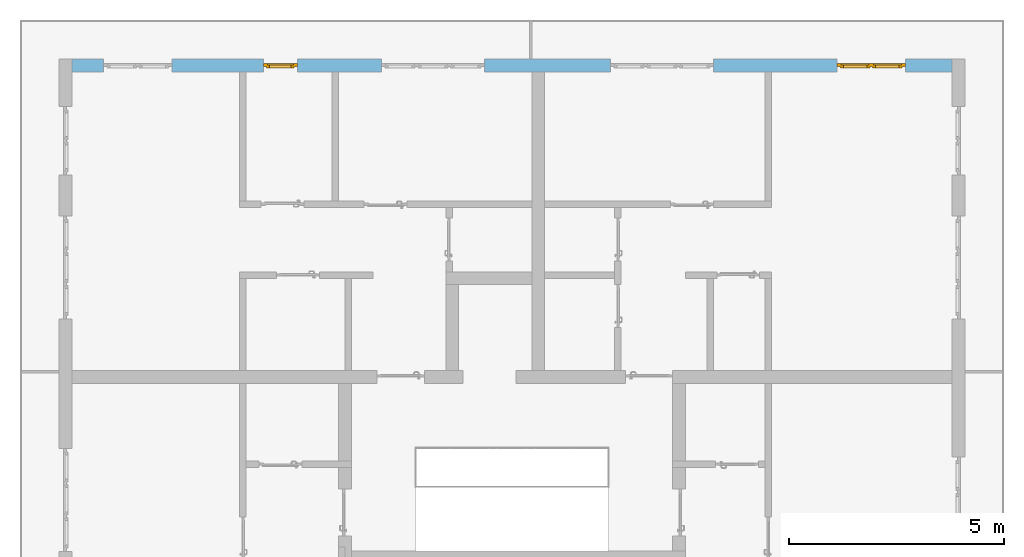
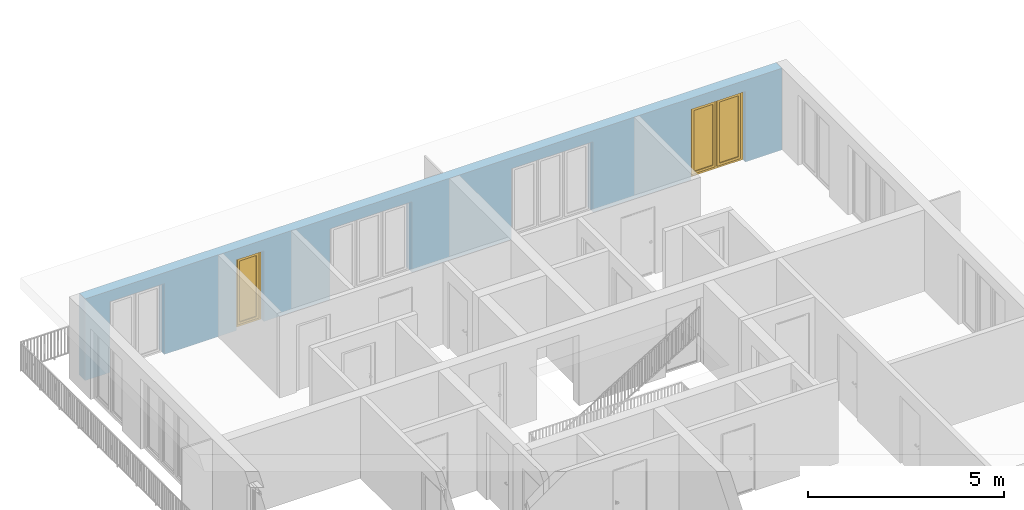
# One storey, part 27 of 54: 2 windows, 5 openings, plus 1 element that does not belong to this part.
"""IFC4 building model written with IfcOpenShell, lengths in metres."""

from ifc_helpers import new_model, entity, si_unit, converted_unit, derived_unit, direction, frame, origin_with_axes, place, context, subcontext, project, spatial, polygons, source, transform, mapped, material, type_object, element, fill, save


model = new_model("IFC4")

# Units and contexts
model_context = context("Model", 3, precision=1e-05, world=origin_with_axes(), true_north=direction((0.0, 1.0)))
body_context = subcontext(model_context, "Body", "Model", "MODEL_VIEW")
ifc_project = project(units=[si_unit("LENGTHUNIT", "METRE"), si_unit("AREAUNIT", "SQUARE_METRE"), si_unit("VOLUMEUNIT", "CUBIC_METRE"), converted_unit("PLANEANGLEUNIT", "DEGREE", entity("IfcPlaneAngleMeasure", 0.0174532925199), si_unit("PLANEANGLEUNIT", "RADIAN"), dimensions=[0, 0, 0, 0, 0, 0, 0]), converted_unit("TIMEUNIT", "Year", entity("IfcTimeMeasure", 31556926.0), si_unit("TIMEUNIT", "SECOND"), dimensions=[0, 0, 1, 0, 0, 0, 0]), si_unit("MASSUNIT", "GRAM", prefix="KILO"), si_unit("THERMODYNAMICTEMPERATUREUNIT", "DEGREE_CELSIUS"), si_unit("LUMINOUSINTENSITYUNIT", "LUMEN"), si_unit("ENERGYUNIT", "JOULE", prefix="MEGA"), derived_unit("THERMALCONDUCTANCEUNIT", [(si_unit("POWERUNIT", "WATT"), 1), (si_unit("LENGTHUNIT", "METRE"), -1), (si_unit("THERMODYNAMICTEMPERATUREUNIT", "KELVIN"), -1)]), derived_unit("SPECIFICHEATCAPACITYUNIT", [(si_unit("ENERGYUNIT", "JOULE"), 1), (si_unit("MASSUNIT", "GRAM", prefix="KILO"), -1), (si_unit("THERMODYNAMICTEMPERATUREUNIT", "KELVIN"), -1)]), derived_unit("MASSDENSITYUNIT", [(si_unit("MASSUNIT", "GRAM", prefix="KILO"), 1), (si_unit("VOLUMEUNIT", "CUBIC_METRE"), -1)])], contexts=[model_context])

# Site, building, storey
site_placement = place(None, origin_with_axes())
site = spatial("IfcSite", under=ifc_project, at=site_placement, CompositionType="ELEMENT")
building_placement = place(site_placement, origin_with_axes())
building = spatial("IfcBuilding", under=site, at=building_placement, CompositionType="ELEMENT")
storey_placement = place(building_placement, frame((0.0, 0.0, 6.29), z_axis=(0.0, 0.0, 1.0), x_axis=(1.0, 0.0, 0.0)))
storey = spatial("IfcBuildingStorey", under=building, at=storey_placement, Name="2. Geschoss", CompositionType="ELEMENT", Elevation=6.29)

# Wall, openings, windows
ifc_material = material()
wall_type = type_object("IfcWallType", Name="300", PredefinedType="NOTDEFINED")
wall_placement = place(storey_placement, frame((-11.7421993804, 8.92118776896, 0.0), z_axis=(0.0, 0.0, 1.0), x_axis=(1.0, 0.0, 0.0)))
wall = element("IfcWall", 1, at=wall_placement, inside=storey, type_object=wall_type, material=ifc_material, Name="Wand-001", PredefinedType="NOTDEFINED", context=body_context, shape_type="Tessellation", body=[
    polygons([(15.23, -0.1, 0.0), (15.23, -0.3, 0.0), (15.23, -0.3, 2.2), (15.23, 0.0, 2.2), (15.23, 0.0, 0.0), (18.102139809, 0.0, 0.0), (18.102139809, -0.3, 0.0), (18.102139809, -0.3, 2.2), (19.702139809, -0.3, 2.2), (19.702139809, -0.3, 0.0), (20.78, -0.3, 0.0), (20.78, -0.3, 2.54), (0.3, -0.3, 2.54), (0.3, -0.3, 0.0), (1.0288518641, -0.3, 0.0), (1.0288518641, -0.3, 2.2), (2.6288518641, -0.3, 2.2), (2.6288518641, -0.3, 0.0), (4.75, -0.3, 0.0), (4.75, -0.3, 2.2), (5.55, -0.3, 2.2), (5.55, -0.3, 0.0), (7.50089858046, -0.3, 0.0), (7.50089858046, -0.3, 2.2), (9.90089858046, -0.3, 2.2), (9.90089858046, -0.3, 0.0), (12.83, -0.3, 0.0), (12.83, -0.3, 2.2), (12.83, 0.0, 2.2), (12.83, 0.0, 0.0), (9.90089858046, 0.0, 0.0), (9.90089858046, 0.0, 2.2), (7.50089858046, 0.0, 2.2), (7.50089858046, 0.0, 0.0), (5.55, 0.0, 0.0), (5.55, 0.0, 2.2), (4.75, 0.0, 2.2), (4.75, 0.0, 0.0), (2.6288518641, 0.0, 0.0), (2.6288518641, 0.0, 2.2), (1.0288518641, 0.0, 2.2), (1.0288518641, 0.0, 0.0), (0.3, 0.0, 0.0), (0.3, 0.0, 2.54), (20.78, 0.0, 2.54), (20.78, 0.0, 0.0), (19.702139809, 0.0, 0.0), (19.702139809, 0.0, 2.2), (18.102139809, 0.0, 2.2), (12.83, -0.1, 0.0)], [[[1, 2, 3, 4, 5]], [[2, 1, 5, 6, 7]], [[3, 2, 7, 8, 9, 10, 11, 12, 13, 14, 15, 16, 17, 18, 19, 20, 21, 22, 23, 24, 25, 26, 27, 28]], [[4, 3, 28, 29]], [[6, 5, 4, 29, 30, 31, 32, 33, 34, 35, 36, 37, 38, 39, 40, 41, 42, 43, 44, 45, 46, 47, 48, 49]], [[6, 49, 8, 7]], [[8, 49, 48, 9]], [[48, 47, 10, 9]], [[46, 11, 10, 47]], [[12, 11, 46, 45]], [[45, 44, 13, 12]], [[44, 43, 14, 13]], [[15, 14, 43, 42]], [[16, 15, 42, 41]], [[40, 17, 16, 41]], [[18, 17, 40, 39]], [[19, 18, 39, 38]], [[20, 19, 38, 37]], [[36, 21, 20, 37]], [[22, 21, 36, 35]], [[22, 35, 34, 23]], [[34, 33, 24, 23]], [[24, 33, 32, 25]], [[32, 31, 26, 25]], [[50, 27, 26, 31, 30]], [[28, 27, 50, 30, 29]]], closed=True),
])
opening_1_placement = place(wall_placement, frame((1.8288518641, 0.0, 0.0), z_axis=(0.0, 0.0, 1.0), x_axis=(1.0, 0.0, 0.0)))
element("IfcOpeningElement", 2, at=opening_1_placement, cuts=wall, Name="Fenster-001", context=body_context, identifier="Reference", shape_type="Tessellation", body=[
    polygons([(-0.8, -0.1, 0.0), (-0.8, -0.1, 2.2), (-0.8, 0.000999999999998, 2.2), (-0.8, 0.000999999999998, 0.0), (-0.8, -0.301, 0.0), (-0.8, -0.301, 2.2), (0.8, -0.1, 2.2), (0.8, 0.000999999999999, 2.2), (0.8, -0.301, 2.2), (0.8, 0.000999999999999, 0.0), (0.8, -0.1, 0.0), (0.8, -0.301, 0.0)], [[[1, 2, 3, 4]], [[2, 1, 5, 6]], [[7, 8, 3, 2, 6, 9]], [[8, 10, 4, 3]], [[1, 4, 10, 11, 12, 5]], [[6, 5, 12, 9]], [[7, 11, 10, 8]], [[11, 7, 9, 12]]], closed=True),
])
opening_2_placement = place(wall_placement, frame((8.70089858046, 0.0, 0.0), z_axis=(0.0, 0.0, 1.0), x_axis=(1.0, 0.0, 0.0)))
element("IfcOpeningElement", 3, at=opening_2_placement, cuts=wall, Name="Fenster-002", context=body_context, identifier="Reference", shape_type="Tessellation", body=[
    polygons([(-1.2, -0.1, 0.0), (-1.2, -0.1, 2.2), (-1.2, 0.000999999999999, 2.2), (-1.2, 0.000999999999999, 0.0), (-1.2, -0.301, 0.0), (-1.2, -0.301, 2.2), (1.2, -0.1, 2.2), (1.2, 0.001, 2.2), (1.2, -0.301, 2.2), (1.2, 0.001, 0.0), (1.2, -0.1, 0.0), (1.2, -0.301, 0.0)], [[[1, 2, 3, 4]], [[2, 1, 5, 6]], [[7, 8, 3, 2, 6, 9]], [[8, 10, 4, 3]], [[1, 4, 10, 11, 12, 5]], [[6, 5, 12, 9]], [[7, 11, 10, 8]], [[11, 7, 9, 12]]], closed=True),
])
opening_3_placement = place(wall_placement, frame((5.15, 0.0, 0.0), z_axis=(0.0, 0.0, 1.0), x_axis=(1.0, 0.0, 0.0)))
opening_3 = element("IfcOpeningElement", 4, at=opening_3_placement, cuts=wall, Name="Fenster-003", context=body_context, identifier="Reference", shape_type="Tessellation", body=[
    polygons([(-0.4, -0.1, 0.0), (-0.4, -0.1, 2.2), (-0.4, 0.001, 2.2), (-0.4, 0.001, 0.0), (-0.4, -0.301, 0.0), (-0.4, -0.301, 2.2), (0.4, -0.1, 2.2), (0.4, 0.001, 2.2), (0.4, -0.301, 2.2), (0.4, 0.001, 0.0), (0.4, -0.1, 0.0), (0.4, -0.301, 0.0)], [[[1, 2, 3, 4]], [[2, 1, 5, 6]], [[7, 8, 3, 2, 6, 9]], [[8, 10, 4, 3]], [[1, 4, 10, 11, 12, 5]], [[6, 5, 12, 9]], [[7, 11, 10, 8]], [[11, 7, 9, 12]]], closed=True),
])
opening_4_placement = place(wall_placement, frame((18.902139809, 0.0, 0.0), z_axis=(0.0, 0.0, 1.0), x_axis=(1.0, 0.0, 0.0)))
opening_4 = element("IfcOpeningElement", 5, at=opening_4_placement, cuts=wall, Name="Fenster-001", context=body_context, identifier="Reference", shape_type="Tessellation", body=[
    polygons([(-0.8, -0.1, 0.0), (-0.8, -0.1, 2.2), (-0.8, 0.001, 2.2), (-0.8, 0.001, 0.0), (-0.8, -0.301, 0.0), (-0.8, -0.301, 2.2), (0.8, -0.1, 2.2), (0.8, 0.001, 2.2), (0.8, -0.301, 2.2), (0.8, 0.001, 0.0), (0.8, -0.1, 0.0), (0.8, -0.301, 0.0)], [[[1, 2, 3, 4]], [[2, 1, 5, 6]], [[7, 8, 3, 2, 6, 9]], [[8, 10, 4, 3]], [[1, 4, 10, 11, 12, 5]], [[6, 5, 12, 9]], [[7, 11, 10, 8]], [[11, 7, 9, 12]]], closed=True),
])
opening_5_placement = place(wall_placement, frame((14.03, 0.0, 0.0), z_axis=(0.0, 0.0, 1.0), x_axis=(1.0, 0.0, 0.0)))
element("IfcOpeningElement", 6, at=opening_5_placement, cuts=wall, Name="Fenster-002", context=body_context, identifier="Reference", shape_type="Tessellation", body=[
    polygons([(-1.2, -0.1, 0.0), (-1.2, -0.1, 2.2), (-1.2, 0.001, 2.2), (-1.2, 0.001, 0.0), (-1.2, -0.301, 0.0), (-1.2, -0.301, 2.2), (1.2, -0.1, 2.2), (1.2, 0.001, 2.2), (1.2, -0.301, 2.2), (1.2, 0.001, 0.0), (1.2, -0.1, 0.0), (1.2, -0.301, 0.0)], [[[1, 2, 3, 4]], [[2, 1, 5, 6]], [[7, 8, 3, 2, 6, 9]], [[8, 10, 4, 3]], [[1, 4, 10, 11, 12, 5]], [[6, 5, 12, 9]], [[7, 11, 10, 8]], [[11, 7, 9, 12]]], closed=True),
])
window_type_1 = type_object("IfcWindowType", Name="2-1+1 26", PartitioningType="DOUBLE_PANEL_VERTICAL", PredefinedType="WINDOW")
shared_shape_1 = source(origin_with_axes(), body_context, "Body", "Tessellation", [
    polygons([(-0.8, -0.07, 0.0), (-0.8, 0.0, 0.0), (-0.7, 0.0, 0.1), (-0.7, -0.07, 0.1), (-0.8, -0.07, 2.2), (-0.8, 0.0, 2.2), (-0.7, 0.0, 2.1), (-0.7, -0.07, 2.1)], [[[1, 2, 3, 4]], [[5, 6, 2, 1]], [[2, 6, 7, 3]], [[4, 3, 7, 8]], [[1, 4, 8, 5]], [[8, 7, 6, 5]]], closed=True),
    polygons([(0.8, -0.07, 0.0), (0.8, 0.0, 0.0), (0.8, 0.0, 2.2), (0.8, -0.07, 2.2), (0.7, -0.07, 0.1), (0.7, 0.0, 0.1), (0.7, 0.0, 2.1), (0.7, -0.07, 2.1)], [[[1, 2, 3, 4]], [[5, 6, 2, 1]], [[2, 6, 7, 3]], [[4, 3, 7, 8]], [[1, 4, 8, 5]], [[8, 7, 6, 5]]], closed=True),
    polygons([(-0.8, -0.07, 0.0), (-0.8, 0.0, 0.0), (0.8, 0.0, 0.0), (0.8, -0.07, 0.0), (-0.7, -0.07, 0.1), (-0.7, 0.0, 0.1), (-0.05, 0.0, 0.1), (0.05, 0.0, 0.1), (0.7, 0.0, 0.1), (0.7, -0.07, 0.1), (0.05, -0.07, 0.1), (-0.05, -0.07, 0.1)], [[[1, 2, 3, 4]], [[5, 6, 2, 1]], [[2, 6, 7, 8, 9, 3]], [[4, 3, 9, 10]], [[1, 4, 10, 11, 12, 5]], [[12, 7, 6, 5]], [[11, 8, 7, 12]], [[10, 9, 8, 11]]], closed=True),
    polygons([(-0.8, -0.07, 2.2), (-0.8, 0.0, 2.2), (-0.7, 0.0, 2.1), (-0.7, -0.07, 2.1), (0.8, -0.07, 2.2), (0.8, 0.0, 2.2), (0.7, 0.0, 2.1), (0.05, 0.0, 2.1), (-0.05, 0.0, 2.1), (-0.05, -0.07, 2.1), (0.05, -0.07, 2.1), (0.7, -0.07, 2.1)], [[[1, 2, 3, 4]], [[5, 6, 2, 1]], [[2, 6, 7, 8, 9, 3]], [[4, 3, 9, 10]], [[1, 4, 10, 11, 12, 5]], [[12, 7, 6, 5]], [[11, 8, 7, 12]], [[10, 9, 8, 11]]], closed=True),
    polygons([(-0.05, -0.07, 0.1), (-0.05, 0.0, 0.1), (0.05, 0.0, 0.1), (0.05, -0.07, 0.1), (-0.05, -0.07, 2.1), (-0.05, 0.0, 2.1), (0.05, 0.0, 2.1), (0.05, -0.07, 2.1)], [[[1, 2, 3, 4]], [[5, 6, 2, 1]], [[2, 6, 7, 3]], [[4, 3, 7, 8]], [[1, 4, 8, 5]], [[8, 7, 6, 5]]], closed=True),
    polygons([(-0.72, 0.0, 0.08), (-0.72, 0.03, 0.08), (-0.65, 0.03, 0.15), (-0.65, 0.0, 0.15), (-0.72, 0.0, 2.12), (-0.72, 0.03, 2.12), (-0.65, 0.03, 2.05), (-0.65, 0.0, 2.05)], [[[1, 2, 3, 4]], [[5, 6, 2, 1]], [[2, 6, 7, 3]], [[4, 3, 7, 8]], [[1, 4, 8, 5]], [[8, 7, 6, 5]]], closed=True),
    polygons([(-0.03, 0.0, 0.08), (-0.1, 0.0, 0.15), (-0.1, 0.03, 0.15), (-0.03, 0.03, 0.08), (-0.03, 0.0, 2.12), (-0.1, 0.0, 2.05), (-0.1, 0.03, 2.05), (-0.03, 0.03, 2.12)], [[[1, 2, 3, 4]], [[1, 5, 6, 2]], [[2, 6, 7, 3]], [[4, 3, 7, 8]], [[5, 1, 4, 8]], [[6, 5, 8, 7]]], closed=True),
    polygons([(-0.72, 0.0, 0.08), (-0.72, 0.03, 0.08), (-0.03, 0.03, 0.08), (-0.03, 0.0, 0.08), (-0.65, 0.0, 0.15), (-0.65, 0.03, 0.15), (-0.1, 0.03, 0.15), (-0.1, 0.0, 0.15)], [[[1, 2, 3, 4]], [[5, 6, 2, 1]], [[2, 6, 7, 3]], [[4, 3, 7, 8]], [[1, 4, 8, 5]], [[8, 7, 6, 5]]], closed=True),
    polygons([(-0.72, 0.0, 2.12), (-0.03, 0.0, 2.12), (-0.03, 0.03, 2.12), (-0.72, 0.03, 2.12), (-0.65, 0.0, 2.05), (-0.1, 0.0, 2.05), (-0.1, 0.03, 2.05), (-0.65, 0.03, 2.05)], [[[1, 2, 3, 4]], [[1, 5, 6, 2]], [[2, 6, 7, 3]], [[4, 3, 7, 8]], [[5, 1, 4, 8]], [[6, 5, 8, 7]]], closed=True),
    polygons([(-0.7, -0.03, 0.1), (-0.7, 0.0, 0.1), (-0.65, 0.0, 0.15), (-0.65, -0.03, 0.15), (-0.7, -0.03, 2.1), (-0.7, 0.0, 2.1), (-0.65, 0.0, 2.05), (-0.65, -0.03, 2.05)], [[[1, 2, 3, 4]], [[5, 6, 2, 1]], [[2, 6, 7, 3]], [[4, 3, 7, 8]], [[1, 4, 8, 5]], [[8, 7, 6, 5]]], closed=True),
    polygons([(-0.05, -0.03, 0.1), (-0.1, -0.03, 0.15), (-0.1, 0.0, 0.15), (-0.05, 0.0, 0.1), (-0.05, -0.03, 2.1), (-0.1, -0.03, 2.05), (-0.1, 0.0, 2.05), (-0.05, 0.0, 2.1)], [[[1, 2, 3, 4]], [[1, 5, 6, 2]], [[2, 6, 7, 3]], [[4, 3, 7, 8]], [[5, 1, 4, 8]], [[6, 5, 8, 7]]], closed=True),
    polygons([(-0.7, -0.03, 0.1), (-0.7, 0.0, 0.1), (-0.05, 0.0, 0.1), (-0.05, -0.03, 0.1), (-0.65, -0.03, 0.15), (-0.65, 0.0, 0.15), (-0.1, 0.0, 0.15), (-0.1, -0.03, 0.15)], [[[1, 2, 3, 4]], [[5, 6, 2, 1]], [[2, 6, 7, 3]], [[4, 3, 7, 8]], [[1, 4, 8, 5]], [[8, 7, 6, 5]]], closed=True),
    polygons([(-0.7, -0.03, 2.1), (-0.05, -0.03, 2.1), (-0.05, 0.0, 2.1), (-0.7, 0.0, 2.1), (-0.65, -0.03, 2.05), (-0.1, -0.03, 2.05), (-0.1, 0.0, 2.05), (-0.65, 0.0, 2.05)], [[[1, 2, 3, 4]], [[1, 5, 6, 2]], [[2, 6, 7, 3]], [[4, 3, 7, 8]], [[5, 1, 4, 8]], [[6, 5, 8, 7]]], closed=True),
    polygons([(-0.65, -0.005, 0.15), (-0.65, 0.005, 0.15), (-0.1, 0.005, 0.15), (-0.1, -0.005, 0.15), (-0.65, -0.005, 2.05), (-0.65, 0.005, 2.05), (-0.1, 0.005, 2.05), (-0.1, -0.005, 2.05)], [[[1, 2, 3, 4]], [[5, 6, 2, 1]], [[2, 6, 7, 3]], [[4, 3, 7, 8]], [[1, 4, 8, 5]], [[8, 7, 6, 5]]], closed=True),
    polygons([(0.03, 0.0, 0.08), (0.03, 0.03, 0.08), (0.1, 0.03, 0.15), (0.1, 0.0, 0.15), (0.03, 0.0, 2.12), (0.03, 0.03, 2.12), (0.1, 0.03, 2.05), (0.1, 0.0, 2.05)], [[[1, 2, 3, 4]], [[5, 6, 2, 1]], [[2, 6, 7, 3]], [[4, 3, 7, 8]], [[1, 4, 8, 5]], [[8, 7, 6, 5]]], closed=True),
    polygons([(0.72, 0.0, 0.08), (0.65, 0.0, 0.15), (0.65, 0.03, 0.15), (0.72, 0.03, 0.08), (0.72, 0.0, 2.12), (0.65, 0.0, 2.05), (0.65, 0.03, 2.05), (0.72, 0.03, 2.12)], [[[1, 2, 3, 4]], [[1, 5, 6, 2]], [[2, 6, 7, 3]], [[4, 3, 7, 8]], [[5, 1, 4, 8]], [[6, 5, 8, 7]]], closed=True),
    polygons([(0.03, 0.0, 0.08), (0.03, 0.03, 0.08), (0.72, 0.03, 0.08), (0.72, 0.0, 0.08), (0.1, 0.0, 0.15), (0.1, 0.03, 0.15), (0.65, 0.03, 0.15), (0.65, 0.0, 0.15)], [[[1, 2, 3, 4]], [[5, 6, 2, 1]], [[2, 6, 7, 3]], [[4, 3, 7, 8]], [[1, 4, 8, 5]], [[8, 7, 6, 5]]], closed=True),
    polygons([(0.03, 0.0, 2.12), (0.72, 0.0, 2.12), (0.72, 0.03, 2.12), (0.03, 0.03, 2.12), (0.1, 0.0, 2.05), (0.65, 0.0, 2.05), (0.65, 0.03, 2.05), (0.1, 0.03, 2.05)], [[[1, 2, 3, 4]], [[1, 5, 6, 2]], [[2, 6, 7, 3]], [[4, 3, 7, 8]], [[5, 1, 4, 8]], [[6, 5, 8, 7]]], closed=True),
    polygons([(0.05, -0.03, 0.1), (0.05, 0.0, 0.1), (0.1, 0.0, 0.15), (0.1, -0.03, 0.15), (0.05, -0.03, 2.1), (0.05, 0.0, 2.1), (0.1, 0.0, 2.05), (0.1, -0.03, 2.05)], [[[1, 2, 3, 4]], [[5, 6, 2, 1]], [[2, 6, 7, 3]], [[4, 3, 7, 8]], [[1, 4, 8, 5]], [[8, 7, 6, 5]]], closed=True),
    polygons([(0.7, -0.03, 0.1), (0.65, -0.03, 0.15), (0.65, 0.0, 0.15), (0.7, 0.0, 0.1), (0.7, -0.03, 2.1), (0.65, -0.03, 2.05), (0.65, 0.0, 2.05), (0.7, 0.0, 2.1)], [[[1, 2, 3, 4]], [[1, 5, 6, 2]], [[2, 6, 7, 3]], [[4, 3, 7, 8]], [[5, 1, 4, 8]], [[6, 5, 8, 7]]], closed=True),
    polygons([(0.05, -0.03, 0.1), (0.05, 0.0, 0.1), (0.7, 0.0, 0.1), (0.7, -0.03, 0.1), (0.1, -0.03, 0.15), (0.1, 0.0, 0.15), (0.65, 0.0, 0.15), (0.65, -0.03, 0.15)], [[[1, 2, 3, 4]], [[5, 6, 2, 1]], [[2, 6, 7, 3]], [[4, 3, 7, 8]], [[1, 4, 8, 5]], [[8, 7, 6, 5]]], closed=True),
    polygons([(0.05, -0.03, 2.1), (0.7, -0.03, 2.1), (0.7, 0.0, 2.1), (0.05, 0.0, 2.1), (0.1, -0.03, 2.05), (0.65, -0.03, 2.05), (0.65, 0.0, 2.05), (0.1, 0.0, 2.05)], [[[1, 2, 3, 4]], [[1, 5, 6, 2]], [[2, 6, 7, 3]], [[4, 3, 7, 8]], [[5, 1, 4, 8]], [[6, 5, 8, 7]]], closed=True),
    polygons([(0.1, -0.005, 0.15), (0.1, 0.005, 0.15), (0.65, 0.005, 0.15), (0.65, -0.005, 0.15), (0.1, -0.005, 2.05), (0.1, 0.005, 2.05), (0.65, 0.005, 2.05), (0.65, -0.005, 2.05)], [[[1, 2, 3, 4]], [[5, 6, 2, 1]], [[2, 6, 7, 3]], [[4, 3, 7, 8]], [[1, 4, 8, 5]], [[8, 7, 6, 5]]], closed=True),
])
window_1_placement = place(opening_4_placement, frame((0.8, 0.0, 0.0), z_axis=(0.0, 0.0, 1.0), x_axis=(-1.0, 0.0, 0.0)))
window_1 = element("IfcWindow", 7, at=window_1_placement, inside=storey, type_object=window_type_1, Name="Fenster-001", OverallHeight=2.2, OverallWidth=1.6, PredefinedType="WINDOW", context=body_context, shape_type="MappedRepresentation", body=[
    mapped(shared_shape_1, transform((0.8, 0.17, 0.0))),
])
fill(opening_4, window_1)
window_type_2 = type_object("IfcWindowType", Name="1-26", PartitioningType="SINGLE_PANEL", PredefinedType="WINDOW")
shared_shape_2 = source(origin_with_axes(), body_context, "Body", "Tessellation", [
    polygons([(0.4, -0.07, 0.0), (0.3, -0.07, 0.1), (0.3, 0.0, 0.1), (0.4, 0.0, 0.0), (0.4, -0.07, 2.2), (0.3, -0.07, 2.1), (0.3, 0.0, 2.1), (0.4, 0.0, 2.2)], [[[1, 2, 3, 4]], [[1, 5, 6, 2]], [[2, 6, 7, 3]], [[4, 3, 7, 8]], [[5, 1, 4, 8]], [[6, 5, 8, 7]]], closed=True),
    polygons([(-0.4, -0.07, 0.0), (-0.4, -0.07, 2.2), (-0.4, 0.0, 2.2), (-0.4, 0.0, 0.0), (-0.3, -0.07, 0.1), (-0.3, -0.07, 2.1), (-0.3, 0.0, 2.1), (-0.3, 0.0, 0.1)], [[[1, 2, 3, 4]], [[1, 5, 6, 2]], [[2, 6, 7, 3]], [[4, 3, 7, 8]], [[5, 1, 4, 8]], [[6, 5, 8, 7]]], closed=True),
    polygons([(0.4, -0.07, 0.0), (-0.4, -0.07, 0.0), (-0.4, 0.0, 0.0), (0.4, 0.0, 0.0), (0.3, -0.07, 0.1), (0.0, -0.07, 0.1), (-0.3, -0.07, 0.1), (-0.3, 0.0, 0.1), (0.0, 0.0, 0.1), (0.3, 0.0, 0.1)], [[[1, 2, 3, 4]], [[1, 5, 6, 7, 2]], [[2, 7, 8, 3]], [[4, 3, 8, 9, 10]], [[5, 1, 4, 10]], [[6, 5, 10, 9]], [[7, 6, 9, 8]]], closed=True),
    polygons([(0.4, -0.07, 2.2), (0.3, -0.07, 2.1), (0.3, 0.0, 2.1), (0.4, 0.0, 2.2), (-0.4, -0.07, 2.2), (-0.3, -0.07, 2.1), (0.0, -0.07, 2.1), (0.0, 0.0, 2.1), (-0.3, 0.0, 2.1), (-0.4, 0.0, 2.2)], [[[1, 2, 3, 4]], [[1, 5, 6, 7, 2]], [[2, 7, 8, 3]], [[4, 3, 8, 9, 10]], [[5, 1, 4, 10]], [[6, 5, 10, 9]], [[7, 6, 9, 8]]], closed=True),
    polygons([(0.32, 0.0, 0.08), (0.25, 0.0, 0.15), (0.25, 0.03, 0.15), (0.32, 0.03, 0.08), (0.32, 0.0, 2.12), (0.25, 0.0, 2.05), (0.25, 0.03, 2.05), (0.32, 0.03, 2.12)], [[[1, 2, 3, 4]], [[1, 5, 6, 2]], [[2, 6, 7, 3]], [[4, 3, 7, 8]], [[5, 1, 4, 8]], [[6, 5, 8, 7]]], closed=True),
    polygons([(-0.32, 0.0, 0.08), (-0.32, 0.03, 0.08), (-0.25, 0.03, 0.15), (-0.25, 0.0, 0.15), (-0.32, 0.0, 2.12), (-0.32, 0.03, 2.12), (-0.25, 0.03, 2.05), (-0.25, 0.0, 2.05)], [[[1, 2, 3, 4]], [[5, 6, 2, 1]], [[2, 6, 7, 3]], [[4, 3, 7, 8]], [[1, 4, 8, 5]], [[8, 7, 6, 5]]], closed=True),
    polygons([(0.32, 0.0, 0.08), (-0.32, 0.0, 0.08), (-0.32, 0.03, 0.08), (0.32, 0.03, 0.08), (0.25, 0.0, 0.15), (-0.25, 0.0, 0.15), (-0.25, 0.03, 0.15), (0.25, 0.03, 0.15)], [[[1, 2, 3, 4]], [[1, 5, 6, 2]], [[2, 6, 7, 3]], [[4, 3, 7, 8]], [[5, 1, 4, 8]], [[6, 5, 8, 7]]], closed=True),
    polygons([(0.32, 0.0, 2.12), (0.32, 0.03, 2.12), (-0.32, 0.03, 2.12), (-0.32, 0.0, 2.12), (0.25, 0.0, 2.05), (0.25, 0.03, 2.05), (-0.25, 0.03, 2.05), (-0.25, 0.0, 2.05)], [[[1, 2, 3, 4]], [[5, 6, 2, 1]], [[2, 6, 7, 3]], [[4, 3, 7, 8]], [[1, 4, 8, 5]], [[8, 7, 6, 5]]], closed=True),
    polygons([(0.3, -0.03, 0.1), (0.25, -0.03, 0.15), (0.25, 0.0, 0.15), (0.3, 0.0, 0.1), (0.3, -0.03, 2.1), (0.25, -0.03, 2.05), (0.25, 0.0, 2.05), (0.3, 0.0, 2.1)], [[[1, 2, 3, 4]], [[1, 5, 6, 2]], [[2, 6, 7, 3]], [[4, 3, 7, 8]], [[5, 1, 4, 8]], [[6, 5, 8, 7]]], closed=True),
    polygons([(-0.3, -0.03, 0.1), (-0.3, 0.0, 0.1), (-0.25, 0.0, 0.15), (-0.25, -0.03, 0.15), (-0.3, -0.03, 2.1), (-0.3, 0.0, 2.1), (-0.25, 0.0, 2.05), (-0.25, -0.03, 2.05)], [[[1, 2, 3, 4]], [[5, 6, 2, 1]], [[2, 6, 7, 3]], [[4, 3, 7, 8]], [[1, 4, 8, 5]], [[8, 7, 6, 5]]], closed=True),
    polygons([(0.3, -0.03, 0.1), (-0.3, -0.03, 0.1), (-0.3, 0.0, 0.1), (0.3, 0.0, 0.1), (0.25, -0.03, 0.15), (-0.25, -0.03, 0.15), (-0.25, 0.0, 0.15), (0.25, 0.0, 0.15)], [[[1, 2, 3, 4]], [[1, 5, 6, 2]], [[2, 6, 7, 3]], [[4, 3, 7, 8]], [[5, 1, 4, 8]], [[6, 5, 8, 7]]], closed=True),
    polygons([(0.3, -0.03, 2.1), (0.3, 0.0, 2.1), (-0.3, 0.0, 2.1), (-0.3, -0.03, 2.1), (0.25, -0.03, 2.05), (0.25, 0.0, 2.05), (-0.25, 0.0, 2.05), (-0.25, -0.03, 2.05)], [[[1, 2, 3, 4]], [[5, 6, 2, 1]], [[2, 6, 7, 3]], [[4, 3, 7, 8]], [[1, 4, 8, 5]], [[8, 7, 6, 5]]], closed=True),
    polygons([(0.25, -0.005, 0.15), (-0.25, -0.005, 0.15), (-0.25, 0.005, 0.15), (0.25, 0.005, 0.15), (0.25, -0.005, 2.05), (-0.25, -0.005, 2.05), (-0.25, 0.005, 2.05), (0.25, 0.005, 2.05)], [[[1, 2, 3, 4]], [[1, 5, 6, 2]], [[2, 6, 7, 3]], [[4, 3, 7, 8]], [[5, 1, 4, 8]], [[6, 5, 8, 7]]], closed=True),
])
window_2_placement = place(opening_3_placement, frame((0.4, 0.0, 0.0), z_axis=(0.0, 0.0, 1.0), x_axis=(-1.0, 0.0, 0.0)))
window_2 = element("IfcWindow", 8, at=window_2_placement, inside=storey, type_object=window_type_2, Name="Fenster-003", OverallHeight=2.2, OverallWidth=0.8, PredefinedType="WINDOW", context=body_context, shape_type="MappedRepresentation", body=[
    mapped(shared_shape_2, transform((0.4, 0.17, 0.0))),
])
fill(opening_3, window_2)

save(model, "model.ifc")
